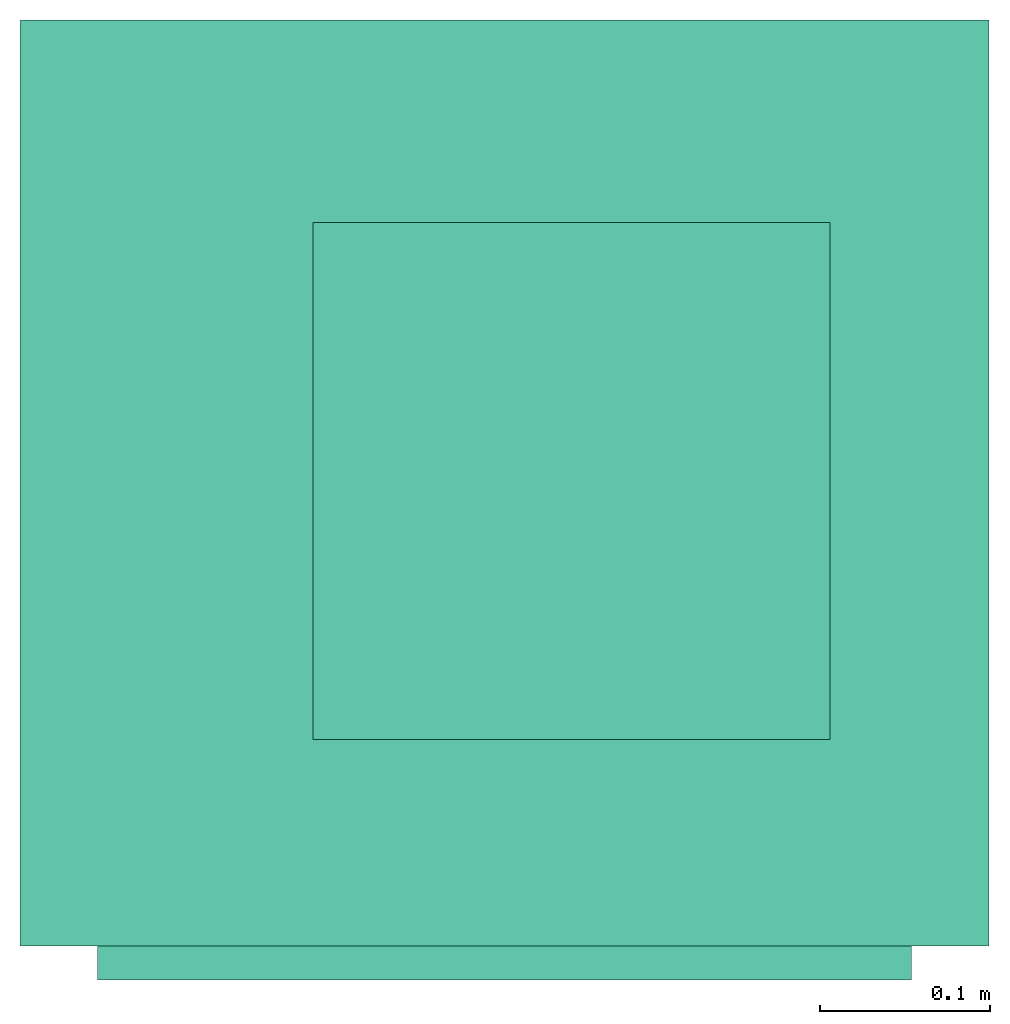
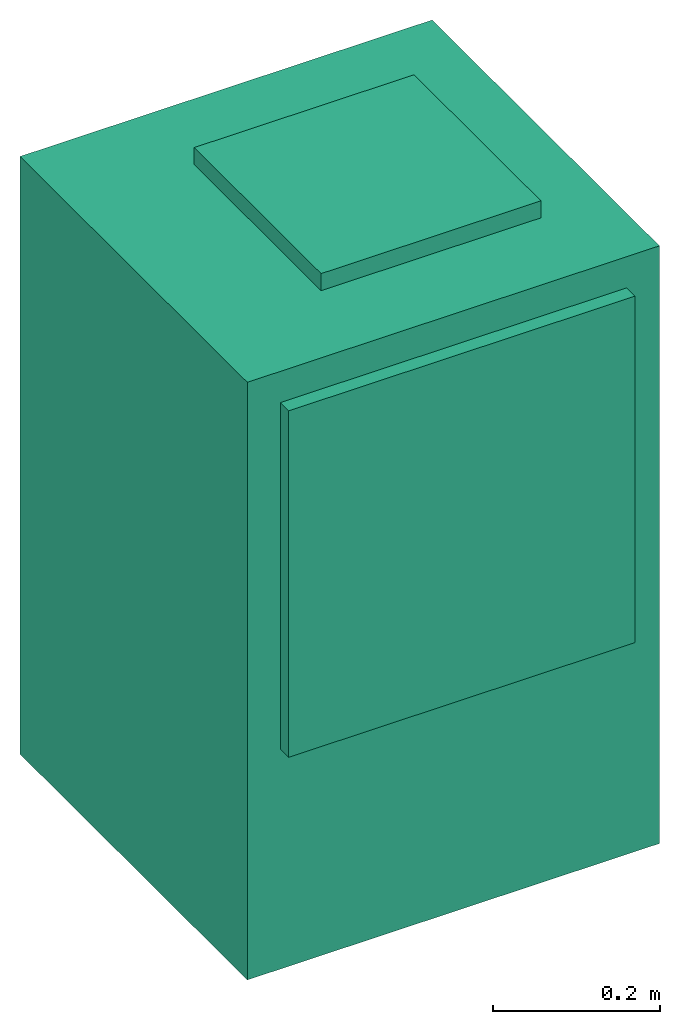
# One storey: 1 energy conversion device.
"""IFC2X3 building model written with IfcOpenShell, lengths in metres."""

from ifc_helpers import new_model, entity, si_unit, converted_unit, origin, origin_with_axes, place, context, subcontext, project, spatial, faceted_brep, type_object, element, save


model = new_model("IFC2X3")

# Units and contexts
model_context = context("Model", 3, precision=1e-05, world=origin())
body_context = subcontext(model_context, "Body", "Model", "MODEL_VIEW")
ifc_project = project(units=[si_unit("LENGTHUNIT", "METRE"), si_unit("AREAUNIT", "SQUARE_METRE"), si_unit("VOLUMEUNIT", "CUBIC_METRE"), converted_unit("PLANEANGLEUNIT", "DEGREE", entity("IfcPlaneAngleMeasure", 0.0174532925199433), si_unit("PLANEANGLEUNIT", "RADIAN"), dimensions=[0, 0, 0, 0, 0, 0, 0]), si_unit("SOLIDANGLEUNIT", "STERADIAN"), si_unit("MASSUNIT", "GRAM"), si_unit("TIMEUNIT", "SECOND"), si_unit("THERMODYNAMICTEMPERATUREUNIT", "DEGREE_CELSIUS"), si_unit("LUMINOUSINTENSITYUNIT", "LUMEN")], contexts=[model_context])

# Site, building, storey
site_placement = place(None, origin_with_axes())
site = spatial("IfcSite", under=ifc_project, at=site_placement, CompositionType="ELEMENT")
building_placement = place(site_placement, origin_with_axes())
building = spatial("IfcBuilding", under=site, at=building_placement, CompositionType="ELEMENT")
storey_placement = place(building_placement, origin_with_axes())
storey = spatial("IfcBuildingStorey", under=building, at=storey_placement, CompositionType="ELEMENT", Elevation=0.0)

# Energy conversion device
heat_exchanger_type = type_object("IfcHeatExchangerType", Name="Vertical Closet Water Source Heat Pump", PredefinedType="NOTDEFINED")
energy_conversion_device_placement = place(storey_placement, origin_with_axes())
element("IfcEnergyConversionDevice", 1, at=energy_conversion_device_placement, inside=storey, type_object=heat_exchanger_type, Name="Vertical Closet Water Source Heat Pump", context=body_context, shape_type="Brep", body=[
    faceted_brep([(0.240029922485352, -0.262890033912658, 0.830580019378663), (0.240029922485352, -0.282890024375916, 0.830580019378663), (0.240029922485352, -0.282890024375916, 0.322579995155334), (0.240029922485352, -0.262890033912658, 0.322579995155334), (-0.240030067825317, -0.262890033912658, 0.830580019378663), (-0.240030067825317, -0.282890024375916, 0.830580019378663), (-0.240030067825317, -0.262890033912658, 0.322579995155334), (-0.240030067825317, -0.282890024375916, 0.322579995155334), (-0.227330067825317, -0.282890024375916, 0.335279995155334), (-0.227330067825317, -0.282890024375916, 0.817880019378663), (0.227329922485352, -0.282890024375916, 0.335279995155334), (0.227329922485352, -0.282890024375916, 0.817880019378663), (0.227329922485352, -0.262890033912658, 0.335279995155334), (0.227329922485352, -0.262890033912658, 0.817880019378663), (-0.227330067825317, -0.262890033912658, 0.817880019378663), (-0.227330067825317, -0.262890033912658, 0.335279995155334)], [[[0, 1, 2]], [[2, 3, 0]], [[4, 5, 1]], [[1, 0, 4]], [[6, 7, 5]], [[5, 4, 6]], [[3, 2, 7]], [[7, 6, 3]], [[5, 7, 8]], [[8, 9, 5]], [[10, 8, 7]], [[1, 5, 9]], [[11, 10, 2]], [[2, 1, 11]], [[7, 2, 10]], [[9, 11, 1]], [[12, 13, 0]], [[0, 3, 12]], [[6, 12, 3]], [[14, 0, 13]], [[6, 4, 14]], [[14, 15, 6]], [[12, 6, 15]], [[0, 14, 4]], [[15, 14, 9]], [[9, 8, 15]], [[14, 13, 11]], [[11, 9, 14]], [[13, 12, 10]], [[10, 11, 13]], [[12, 15, 8]], [[8, 10, 12]]]),
    faceted_brep([(0.285749927330018, -0.262890033912658, 0.8763), (-0.285750072669982, -0.262890033912658, 0.8763), (-0.285750072669982, -0.262890033912658, -1.80477854883065e-16), (0.285749927330018, -0.262890033912658, -1.80477854883065e-16), (0.285749927330018, 0.283209966087342, 0.8763), (-0.285750072669982, 0.283209966087342, 0.8763), (0.285749927330018, 0.283209966087342, -1.80477854883065e-16), (-0.285750072669982, 0.283209966087342, -1.80477854883065e-16)], [[[0, 1, 2]], [[2, 3, 0]], [[1, 0, 4]], [[4, 5, 1]], [[5, 4, 6]], [[6, 7, 5]], [[1, 5, 7]], [[7, 2, 1]], [[4, 0, 3]], [[3, 6, 4]], [[2, 7, 6]], [[6, 3, 2]]]),
    faceted_brep([(-0.113030067825317, -0.140970041179657, 0.901300024414062), (-0.113030067825317, -0.140970041179657, 0.8763), (0.191769932174682, -0.140970041179657, 0.8763), (0.191769932174682, -0.140970041179657, 0.901300024414062), (-0.113030067825317, 0.163829958820343, 0.901300024414062), (-0.113030067825317, 0.163829958820343, 0.8763), (0.191769932174682, 0.163829958820343, 0.901300024414062), (0.191769932174682, 0.163829958820343, 0.8763)], [[[0, 1, 2]], [[2, 3, 0]], [[4, 5, 1]], [[1, 0, 4]], [[6, 7, 5]], [[5, 4, 6]], [[3, 2, 7]], [[7, 6, 3]], [[3, 6, 4]], [[4, 0, 3]], [[1, 5, 7]], [[7, 2, 1]]]),
    faceted_brep([(-0.227330067825317, -0.282890024375916, 0.335279995155334), (-0.227330067825317, -0.282890024375916, 0.817880019378663), (-0.227330067825317, -0.262890033912658, 0.817880019378663), (-0.227330067825317, -0.262890033912658, 0.335279995155334), (0.227329922485352, -0.282890024375916, 0.817880019378663), (0.227329922485352, -0.262890033912658, 0.817880019378663), (0.227329922485352, -0.282890024375916, 0.335279995155334), (0.227329922485352, -0.262890033912658, 0.335279995155334)], [[[0, 1, 2]], [[2, 3, 0]], [[1, 4, 5]], [[5, 2, 1]], [[4, 6, 7]], [[7, 5, 4]], [[6, 0, 3]], [[3, 7, 6]], [[1, 0, 6]], [[6, 4, 1]], [[2, 7, 3]], [[7, 2, 5]]]),
])

save(model, "model.ifc")
